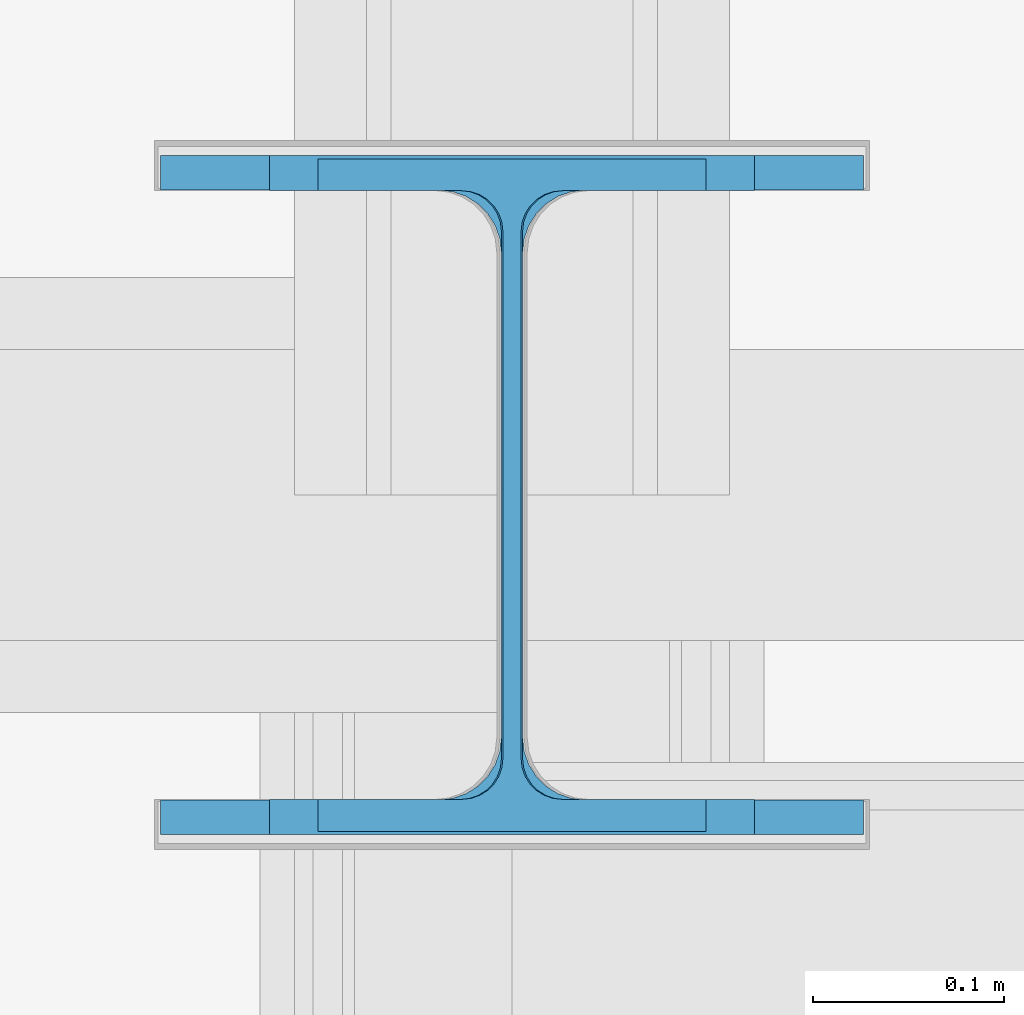
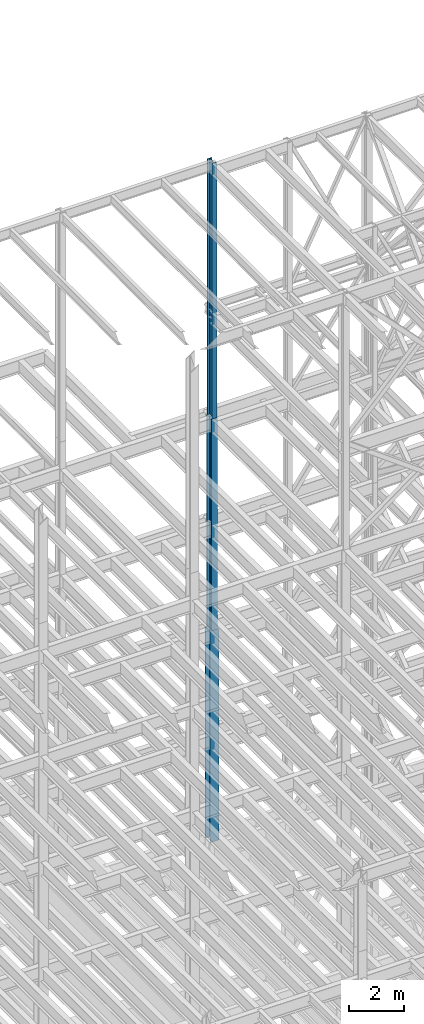
# One storey, part 68 of 150: 3 columns.
"""IFC2X3 building model written with IfcOpenShell, lengths in millimetres."""

from ifc_helpers import new_model, si_unit, frame, origin_with_axes, origin_2d_with_axis, place, context, subcontext, project, spatial, i_section, extrude, material, type_object, element, save


model = new_model("IFC2X3")

# Units and contexts
model_context = context("Model", 3, precision=1e-05, world=origin_with_axes())
body_context = subcontext(model_context, "Body", "Model", "MODEL_VIEW")
ifc_project = project(units=[si_unit("LENGTHUNIT", "METRE", prefix="MILLI"), si_unit("AREAUNIT", "SQUARE_METRE"), si_unit("VOLUMEUNIT", "CUBIC_METRE"), si_unit("MASSUNIT", "GRAM", prefix="KILO"), si_unit("TIMEUNIT", "SECOND"), si_unit("PLANEANGLEUNIT", "RADIAN"), si_unit("SOLIDANGLEUNIT", "STERADIAN"), si_unit("THERMODYNAMICTEMPERATUREUNIT", "DEGREE_CELSIUS"), si_unit("LUMINOUSINTENSITYUNIT", "LUMEN")], contexts=[model_context])

# Site, building, storey
site_placement = place(None, origin_with_axes())
site = spatial("IfcSite", under=ifc_project, at=site_placement, CompositionType="ELEMENT")
building_placement = place(site_placement, origin_with_axes())
building = spatial("IfcBuilding", under=site, at=building_placement, Name="Undefined", CompositionType="ELEMENT")
storey_placement = place(building_placement, origin_with_axes())
storey = spatial("IfcBuildingStorey", under=building, at=storey_placement, Name="Undefined", CompositionType="ELEMENT", Elevation=0.0)

# Columns
ifc_material = material(Name="STEEL/A992")
column_type_1 = type_object("IfcColumnType", Name="W14X53", PredefinedType="NOTDEFINED")
column_1_placement = place(storey_placement, frame((50190.4, 32131.0, 54483.0), z_axis=(0.0, 0.0, 1.0), x_axis=(1.0, 0.0, 0.0)))
element("IfcColumn", 1, at=column_1_placement, inside=storey, type_object=column_type_1, material=ifc_material, Name="COLUMN", ObjectType="W14X53", context=body_context, shape_type="SweptSolid", body=[
    extrude(i_section(OverallWidth=203.2, OverallDepth=352.425, WebThickness=9.5249, FlangeThickness=16.764, FilletRadius=21.336, at=origin_2d_with_axis()), frame((0.0, 0.0, 11430.0), z_axis=(0.0, 0.0, -1.0), x_axis=(-1.0, 0.0, 0.0)), (0.0, 0.0, 1.0), 11430.0),
])
column_type_2 = type_object("IfcColumnType", Name="W14X68", PredefinedType="NOTDEFINED")
column_2_placement = place(storey_placement, frame((50190.4, 32131.0, 45034.2), z_axis=(0.0, 0.0, 1.0), x_axis=(1.0, 0.0, 0.0)))
element("IfcColumn", 2, at=column_2_placement, inside=storey, type_object=column_type_2, material=ifc_material, Name="COLUMN", ObjectType="W14X68", context=body_context, shape_type="SweptSolid", body=[
    extrude(i_section(OverallWidth=254.0, OverallDepth=355.6, WebThickness=11.1125, FlangeThickness=18.288, FilletRadius=21.3994, at=origin_2d_with_axis()), frame((0.0, 0.0, 9448.8), z_axis=(0.0, 0.0, -1.0), x_axis=(-1.0, 0.0, 0.0)), (0.0, 0.0, 1.0), 9448.8),
])
column_type_3 = type_object("IfcColumnType", Name="W14X90", PredefinedType="NOTDEFINED")
column_3_placement = place(storey_placement, frame((50190.4, 32131.0, 35585.4), z_axis=(0.0, 0.0, 1.0), x_axis=(1.0, 0.0, 0.0)))
element("IfcColumn", 3, at=column_3_placement, inside=storey, type_object=column_type_3, material=ifc_material, Name="COLUMN", ObjectType="W14X90", context=body_context, shape_type="SweptSolid", body=[
    extrude(i_section(OverallWidth=368.3, OverallDepth=355.6, WebThickness=11.1125, FlangeThickness=18.034, FilletRadius=32.7659, at=origin_2d_with_axis()), frame((0.0, 0.0, 9448.8), z_axis=(0.0, 0.0, -1.0), x_axis=(-1.0, 0.0, 0.0)), (0.0, 0.0, 1.0), 9448.8),
])

save(model, "model.ifc")
